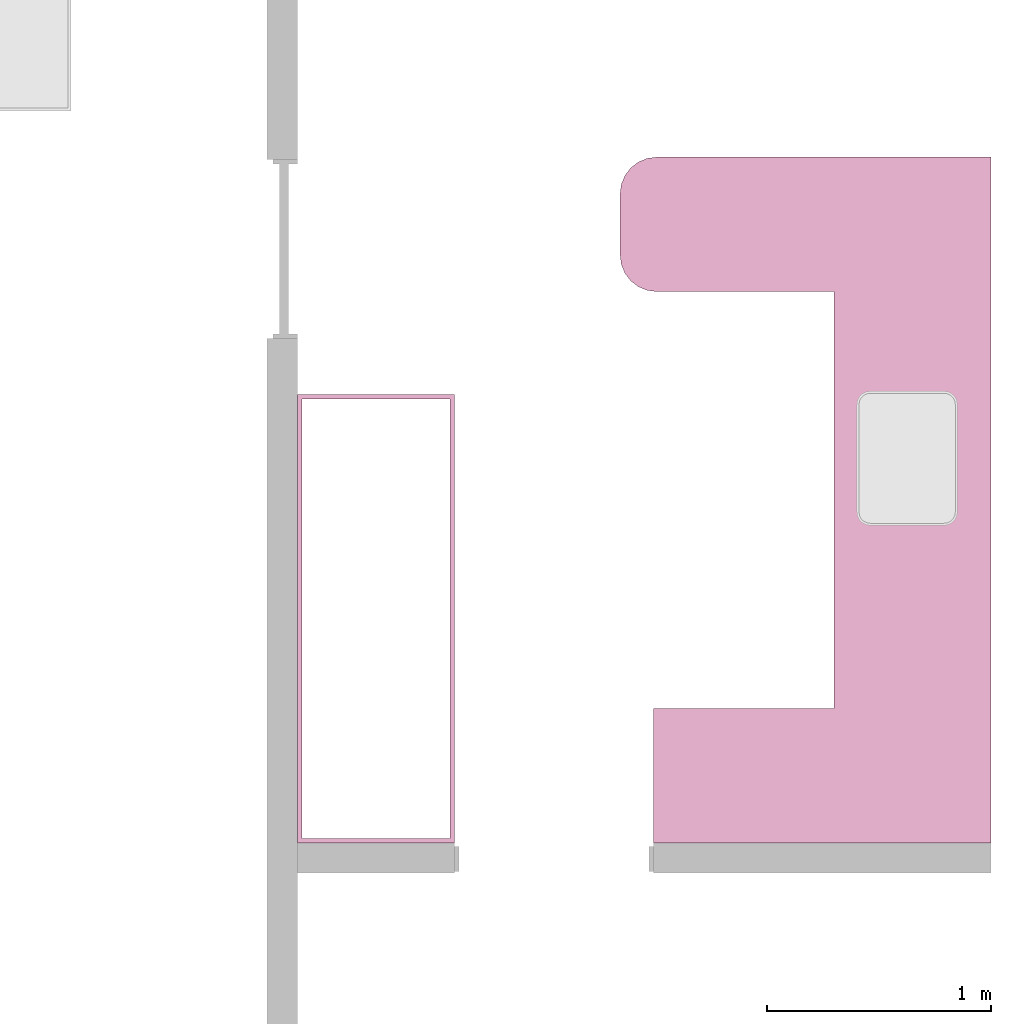
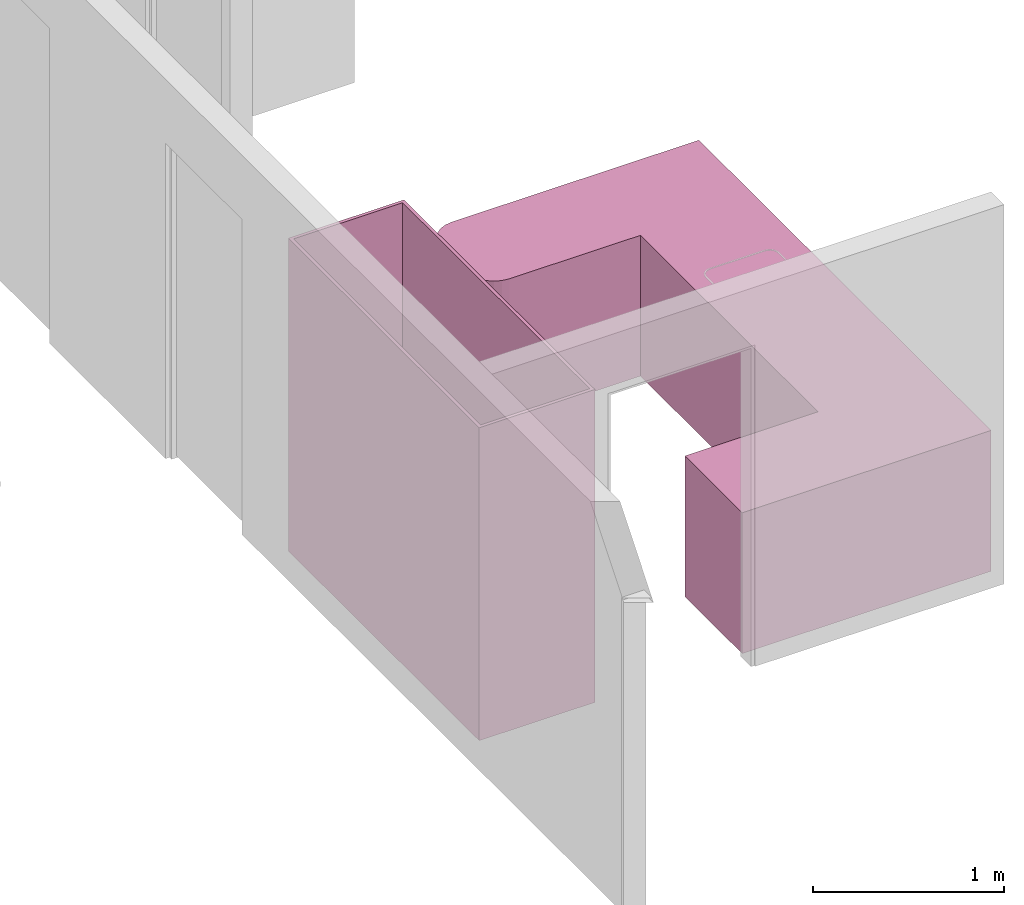
# One storey, part 6 of 6: 2 furniture elements.
"""IFC4 building model written with IfcOpenShell, lengths in millimetres."""

from ifc_helpers import new_model, entity, si_unit, converted_unit, frame, origin_with_axes, origin_2d_with_axis, place, context, subcontext, project, spatial, polygons, element, save


model = new_model("IFC4")

# Units and contexts
model_context = context("Model", 3, precision=1e-05, world=origin_with_axes())
plan_context = context("Plan", 2, precision=1e-05, world=origin_2d_with_axis())
body_context = subcontext(model_context, "Body", "Model", "MODEL_VIEW")
ifc_project = project(units=[si_unit("VOLUMEUNIT", "CUBIC_METRE"), si_unit("LENGTHUNIT", "METRE", prefix="MILLI"), converted_unit("PLANEANGLEUNIT", "degree", entity("IfcReal", 0.0174532925199433), si_unit("PLANEANGLEUNIT", "RADIAN"), dimensions=[0, 0, 0, 0, 0, 0, 0]), si_unit("AREAUNIT", "SQUARE_METRE")], contexts=[model_context, plan_context])

# Site, building, storey
site_placement = place(None, origin_with_axes())
site = spatial("IfcSite", under=ifc_project, at=site_placement)
building_placement = place(site_placement, origin_with_axes())
building = spatial("IfcBuilding", under=site, at=building_placement, Name="Building")
storey_placement = place(building_placement, origin_with_axes())
storey = spatial("IfcBuildingStorey", under=building, at=storey_placement, Name="DEMO")

# Furniture
furniture_1_placement = place(storey_placement, frame((12859.1213226318, 481.667757034302, 450.000047683716), z_axis=(0.0, 0.0, 1.0), x_axis=(7.54979012640431e-08, 0.999999999999997, 0.0)))
element("IfcFurniture", 1, at=furniture_1_placement, inside=storey, Name="Cube", PredefinedType="TABLE", context=body_context, shape_type="Tessellation", body=[
    polygons([(-1000.00006103516, -350.0, -450.0), (-1000.00006103516, -350.0, 450.0), (-1000.00006103516, 350.0, -450.0), (-1000.00006103516, 350.0, 450.0), (2060.0, -350.0, -450.0), (2060.0, -350.0, 450.0), (2060.0, 350.0, -450.0), (2060.0, 350.0, 450.0), (-400.000061035156, 350.0, -450.0), (-400.000061035156, 350.0, 450.0), (-400.000061035156, -350.0, -450.0), (-400.000061035156, -350.0, 450.0), (-1000.00006103516, 1154.9990234375, 450.0), (-1000.00006103516, 1154.9990234375, -450.0), (-400.000061035156, 1154.9990234375, -450.0), (-400.000061035156, 1154.9990234375, 450.0), (1460.00012207031, 350.0, 450.0), (1460.00012207031, -350.0, -450.0), (1460.00012207031, 350.0, -450.0), (1460.00012207031, -350.0, 450.0), (1622.60217285156, 1304.9990234375, 450.0), (1460.00012207031, 1142.39685058594, 450.0), (1580.51782226562, 1299.45849609375, 450.0), (1541.30114746094, 1283.21447753906, 450.0), (1507.62524414062, 1257.3740234375, 450.0), (1481.78479003906, 1223.69799804688, 450.0), (1465.54064941406, 1184.4814453125, 450.0), (2060.0, 1142.39685058594, 450.0), (1897.39782714844, 1304.9990234375, 450.0), (2054.45947265625, 1184.4814453125, 450.0), (2038.21545410156, 1223.69799804688, 450.0), (2012.375, 1257.3740234375, 450.0), (1978.69897460938, 1283.21447753906, 450.0), (1939.482421875, 1299.45849609375, 450.0), (1897.39782714844, 1304.9990234375, -450.0), (2060.0, 1142.39685058594, -450.0), (1939.482421875, 1299.45849609375, -450.0), (1978.69897460938, 1283.21447753906, -450.0), (2012.375, 1257.3740234375, -450.0), (2038.21545410156, 1223.69799804688, -450.0), (2054.45947265625, 1184.4814453125, -450.0), (1460.00012207031, 1142.39685058594, -450.0), (1622.60217285156, 1304.9990234375, -450.0), (1465.54064941406, 1184.4814453125, -450.0), (1481.78479003906, 1223.69799804688, -450.0), (1507.62524414062, 1257.3740234375, -450.0), (1541.30114746094, 1283.21447753906, -450.0), (1580.51782226562, 1299.45849609375, -450.0)], [[[1, 2, 4, 3]], [[7, 19, 42, 44, 45, 46, 47, 48, 43, 35, 37, 38, 39, 40, 41, 36]], [[7, 8, 6, 5]], [[11, 12, 2, 1]], [[19, 7, 5, 18]], [[10, 4, 2, 12]], [[17, 10, 12, 20]], [[3, 9, 11, 1]], [[18, 20, 12, 11]], [[9, 3, 14, 15]], [[14, 13, 16, 15]], [[4, 10, 16, 13]], [[3, 4, 13, 14]], [[10, 9, 15, 16]], [[5, 6, 20, 18]], [[8, 17, 20, 6]], [[9, 19, 18, 11]], [[9, 10, 17, 19]], [[19, 17, 22, 42]], [[8, 7, 36, 28]], [[43, 21, 29, 35]], [[28, 36, 41, 30]], [[30, 41, 40, 31]], [[31, 40, 39, 32]], [[32, 39, 38, 33]], [[33, 38, 37, 34]], [[34, 37, 35, 29]], [[21, 43, 48, 23]], [[23, 48, 47, 24]], [[24, 47, 46, 25]], [[25, 46, 45, 26]], [[26, 45, 44, 27]], [[27, 44, 42, 22]], [[17, 8, 28, 30, 31, 32, 33, 34, 29, 21, 23, 24, 25, 26, 27, 22]]], closed=True),
])
furniture_2_placement = place(storey_placement, frame((10804.1210174561, 1471.66728973389, 1000.0), z_axis=(0.0, 0.0, 1.0), x_axis=(1.0, 0.0, 0.0)))
element("IfcFurniture", 2, at=furniture_2_placement, inside=storey, Name="Cube", PredefinedType="TABLE", context=body_context, shape_type="Tessellation", body=[
    polygons([(-669.998229980469, -10.0000247955322, -999.999938964844), (-669.998229980469, -10.0000247955322, 999.999938964844), (-669.998229980469, 9.99997520446777, -999.999938964844), (-669.998229980469, 9.99997520446777, 999.999938964844), (-9.99998950958252, -9.99992370605469, -999.999938964844), (-9.99998950958252, -9.99992370605469, 999.999938964844), (-9.99998950958252, 10.0000762939453, -999.999938964844), (-9.99998950958252, 10.0000762939453, 999.999938964844), (-669.998413085938, -1990.0, -999.999938964844), (-669.998413085938, -1990.0, 999.999938964844), (-689.998413085938, -1990.0, -999.999938964844), (-689.998413085938, -1990.0, 999.999938964844), (-669.998291015625, 9.99992370605469, -999.999938964844), (-669.998291015625, 9.99992370605469, 999.999938964844), (-689.998291015625, 9.99992370605469, -999.999938964844), (-689.998291015625, 9.99992370605469, 999.999938964844), (9.99980545043945, -1990.0, -999.999938964844), (9.99980545043945, -1990.0, 999.999938964844), (-10.0001945495605, -1990.0, -999.999938964844), (-10.0001945495605, -1990.0, 999.999938964844), (9.99995613098145, 9.99992370605469, -999.999938964844), (9.99995613098145, 9.99992370605469, 999.999938964844), (-10.0000438690186, 9.99992370605469, -999.999938964844), (-10.0000438690186, 9.99992370605469, 999.999938964844), (-669.998413085938, -1989.99938964844, -999.999938964844), (-669.998413085938, -1989.99938964844, 999.999938964844), (-669.998413085938, -1969.99938964844, -999.999938964844), (-669.998413085938, -1969.99938964844, 999.999938964844), (-10.000168800354, -1989.99938964844, -999.999938964844), (-10.000168800354, -1989.99938964844, 999.999938964844), (-10.000168800354, -1969.99938964844, -999.999938964844), (-10.000168800354, -1969.99938964844, 999.999938964844)], [[[1, 2, 4, 3]], [[3, 4, 8, 7]], [[7, 8, 6, 5]], [[5, 6, 2, 1]], [[3, 7, 5, 1]], [[8, 4, 2, 6]], [[9, 10, 12, 11]], [[11, 12, 16, 15]], [[15, 16, 14, 13]], [[13, 14, 10, 9]], [[11, 15, 13, 9]], [[16, 12, 10, 14]], [[17, 18, 20, 19]], [[19, 20, 24, 23]], [[23, 24, 22, 21]], [[21, 22, 18, 17]], [[19, 23, 21, 17]], [[24, 20, 18, 22]], [[25, 26, 28, 27]], [[27, 28, 32, 31]], [[31, 32, 30, 29]], [[29, 30, 26, 25]], [[27, 31, 29, 25]], [[32, 28, 26, 30]]], closed=True),
])

save(model, "model.ifc")
